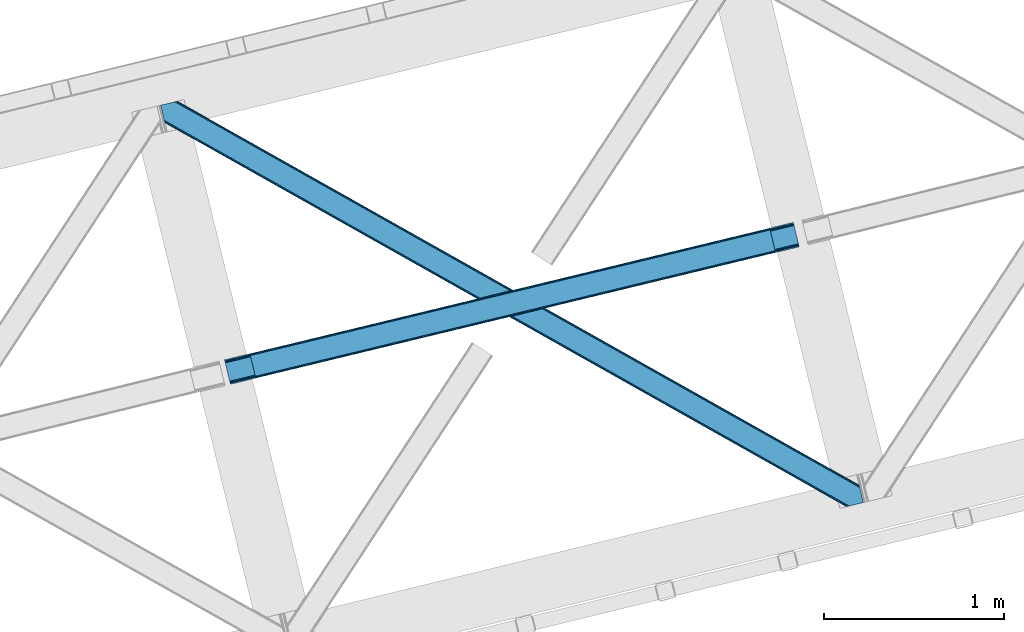
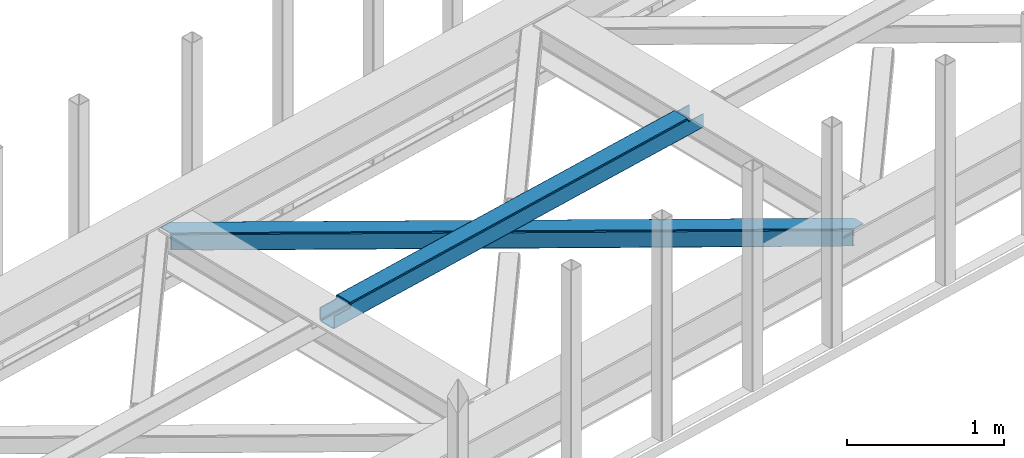
# One storey, part 32 of 66: 1 beam, 1 member.
"""IFC4 building model written with IfcOpenShell, lengths in millimetres."""

from ifc_helpers import new_model, entity, si_unit, converted_unit, derived_unit, direction, frame, origin, place, context, subcontext, project, spatial, triangles, polygons, material, type_object, element, save


model = new_model("IFC4")

# Units and contexts
model_context = context("Model", 3, precision=0.01, world=origin(), true_north=direction((6.12303176911189e-17, 1.0)))
plan_context = context("Plan", 3, precision=0.01, world=origin(), true_north=direction((6.12303176911189e-17, 1.0)))
body_context = subcontext(model_context, "Body", "Model", "MODEL_VIEW")
ifc_project = project(units=[si_unit("LENGTHUNIT", "METRE", prefix="MILLI"), si_unit("AREAUNIT", "SQUARE_METRE"), si_unit("VOLUMEUNIT", "CUBIC_METRE"), converted_unit("PLANEANGLEUNIT", "DEGREE", entity("IfcRatioMeasure", 0.0174532925199433), si_unit("PLANEANGLEUNIT", "RADIAN"), dimensions=[0, 0, 0, 0, 0, 0, 0]), si_unit("MASSUNIT", "GRAM", prefix="KILO"), derived_unit("MASSDENSITYUNIT", [(si_unit("MASSUNIT", "GRAM", prefix="KILO"), 1), (si_unit("LENGTHUNIT", "METRE"), -3)]), derived_unit("MOMENTOFINERTIAUNIT", [(si_unit("LENGTHUNIT", "METRE"), 4)]), si_unit("TIMEUNIT", "SECOND"), si_unit("FREQUENCYUNIT", "HERTZ"), si_unit("THERMODYNAMICTEMPERATUREUNIT", "DEGREE_CELSIUS"), derived_unit("THERMALTRANSMITTANCEUNIT", [(si_unit("MASSUNIT", "GRAM", prefix="KILO"), 1), (si_unit("THERMODYNAMICTEMPERATUREUNIT", "KELVIN"), -1), (si_unit("TIMEUNIT", "SECOND"), -3)]), derived_unit("VOLUMETRICFLOWRATEUNIT", [(si_unit("LENGTHUNIT", "METRE"), 3), (si_unit("TIMEUNIT", "SECOND"), -1)]), derived_unit("MASSFLOWRATEUNIT", [(si_unit("MASSUNIT", "GRAM", prefix="KILO"), 1), (si_unit("TIMEUNIT", "SECOND"), -1)]), derived_unit("ROTATIONALFREQUENCYUNIT", [(si_unit("TIMEUNIT", "SECOND"), -1)]), si_unit("ELECTRICCURRENTUNIT", "AMPERE"), si_unit("ELECTRICVOLTAGEUNIT", "VOLT"), si_unit("POWERUNIT", "WATT"), si_unit("FORCEUNIT", "NEWTON", prefix="KILO"), si_unit("ILLUMINANCEUNIT", "LUX"), si_unit("LUMINOUSFLUXUNIT", "LUMEN"), si_unit("LUMINOUSINTENSITYUNIT", "CANDELA"), derived_unit("USERDEFINED", [(si_unit("MASSUNIT", "GRAM", prefix="KILO"), -1), (si_unit("LENGTHUNIT", "METRE"), -2), (si_unit("TIMEUNIT", "SECOND"), 3), (si_unit("LUMINOUSFLUXUNIT", "LUMEN"), 1)]), derived_unit("LINEARVELOCITYUNIT", [(si_unit("LENGTHUNIT", "METRE"), 1), (si_unit("TIMEUNIT", "SECOND"), -1)]), si_unit("PRESSUREUNIT", "PASCAL"), derived_unit("USERDEFINED", [(si_unit("LENGTHUNIT", "METRE"), -2), (si_unit("MASSUNIT", "GRAM", prefix="KILO"), 1), (si_unit("TIMEUNIT", "SECOND"), -2)]), derived_unit("LINEARFORCEUNIT", [(si_unit("MASSUNIT", "GRAM", prefix="KILO"), 1), (si_unit("LENGTHUNIT", "METRE"), 1), (si_unit("TIMEUNIT", "SECOND"), -2), (si_unit("LENGTHUNIT", "METRE"), -1)]), derived_unit("PLANARFORCEUNIT", [(si_unit("MASSUNIT", "GRAM", prefix="KILO"), 1), (si_unit("LENGTHUNIT", "METRE"), 1), (si_unit("TIMEUNIT", "SECOND"), -2), (si_unit("LENGTHUNIT", "METRE"), -2)])], contexts=[model_context, plan_context])

# Site, building, storey
site_placement = place(None, origin())
site = spatial("IfcSite", under=ifc_project, at=site_placement, CompositionType="ELEMENT")
building_placement = place(site_placement, origin())
building = spatial("IfcBuilding", under=site, at=building_placement, CompositionType="ELEMENT")
storey_placement = place(building_placement, frame((0.0, 0.0, 19800.0)))
storey = spatial("IfcBuildingStorey", under=building, at=storey_placement, Name="06", CompositionType="ELEMENT", Elevation=19800.0)

# Beam
ifc_material = material(Name="Metal painted (White)")
beam_type = type_object("IfcBeamType", PredefinedType="BEAM")
beam_placement = place(storey_placement, frame((-39359.61, 9545.57, 3967.03)))
element("IfcBeam", 1, at=beam_placement, inside=storey, type_object=beam_type, material=ifc_material, ObjectType="Steel Beam", PredefinedType="BEAM", context=body_context, shape_type="Tessellation", body=[
    polygons([(27.353470961905, 23.8030752188062, 7.0000598235344), (28.9394891671779, 17.2966162719668, 8.33217213033355), (3188.12645728267, 780.539347460429, 9.29712245828728), (3186.55413874494, 787.049116173921, 7.96501433595093), (30.2840504779923, 11.7807067185854, 12.1256988935852), (3189.45863568933, 775.020446263414, 13.0906454392703), (31.1824576232485, 8.09509378632021, 17.8031100519825), (3190.34786187874, 771.332615261155, 18.7680537934142), (31.4979362591613, 6.80087863394741, 24.5000712225218), (3190.65875922441, 770.037293293477, 25.465013564638), (1.65778611891462, 129.216694044932, 24.4999947032322), (1.97326475483608, 127.922478892558, 17.8030351506566), (3161.38389125856, 891.219244755388, 18.7680537934142), (3161.0691284579, 892.513632849746, 25.465013564638), (2.87167190008358, 124.23686596029, 12.1256285998416), (3162.27639442246, 887.532205452699, 13.0906454392703), (4.21623321089799, 118.720956406912, 8.3321087323268), (3163.61076243349, 882.013833252429, 9.29712245828728), (5.80225141617086, 112.214497460073, 7.00000455960104), (3165.18384985803, 875.504250297889, 7.96501433595093), (8.66293703438714e-12, 136.017572678875, 17.4999901436355), (0.315478635912791, 134.723357526499, 10.8030305910599), (1.21388578116896, 131.037744594233, 5.12562404024054), (2.55844709199203, 125.521835040854, 1.33210417273009), (4.1444652972649, 119.015376094016, 0.0), (29.0112570808023, 17.002196584861, 6.37660776192206e-05), (30.5972752860752, 10.4957376380216, 1.3321760728811), (31.9418365968809, 4.97982808464235, 5.12570283613275), (32.8402437421458, 1.29421515237713, 10.8031139945301), (33.1557223780586, 3.24860138789518e-12, 17.5000751650737), (33.1557223780586, 1.08286712929839e-12, 104.492615519572), (31.4979362591526, 6.80087863394633, 104.492615519572), (1.6577861188973, 129.21669404493, 104.492615519572), (0.0, 136.017572678875, 104.492615519572), (3159.42728026612, 899.318362001921, 18.4650138731615), (3159.39928415555, 899.311598290844, 115.472391628142), (3161.04315253146, 892.507357204385, 115.472391628137), (3190.63278329797, 770.031017648118, 115.472391628137), (3192.27665167388, 763.226776561658, 115.472391628137), (3192.30464778445, 763.233540272735, 18.4650138731615), (3191.99375043879, 764.528862240413, 11.7680541019377), (3191.10452424939, 768.216693242674, 6.09064574779806), (3189.77234584272, 773.735594439689, 2.29712276681504), (3188.200027305, 780.245363153179, 0.965014644474365), (3163.54200166624, 882.308979450066, 0.965014644474365), (3161.96891424171, 888.818562404604, 2.29712276681504), (3160.63454623068, 894.336934604878, 6.09064574779806), (3159.74204306677, 898.023973907563, 11.7680541019377), (161.750823822574, 38.2692819454433, 104.492615519559), (165.531158526742, 39.1825906585835, 106.103528223035), (169.311493230918, 40.0958993717227, 107.714440926506), (170.877359135682, 40.4742042273367, 111.603528223046), (172.443225040463, 40.8525090829539, 115.492615519574), (3059.3968274947, 738.325110290198, 116.424924587822), (3059.39682749469, 738.325110290198, 115.472391628142), (163.408609941463, 31.4684033114959, 104.492615519598), (167.188944645622, 32.3817120246361, 106.103528223082), (170.969279349807, 33.2950207377775, 107.71444092654), (172.535145254588, 33.6733255933936, 111.603528223046), (174.10101115936, 34.0516304490098, 115.492615519574), (3061.0546136136, 731.524231656253, 115.472391628142), (3061.0546136136, 731.524231656253, 123.424929147419), (174.10101115936, 34.0516304490109, 122.543130490485), (140.945288781319, 170.069203127884, 115.492615519574), (142.60293422888, 163.268906601355, 115.492734192455), (142.918741097907, 161.973333198349, 122.239852351631), (143.816960681394, 158.288496409301, 127.91742174054), (145.161521992199, 152.772586855922, 131.710948503787), (146.747540197472, 146.266127909081, 133.04306081059), (168.298759743206, 57.8547056678149, 133.043116074524), (169.884777948479, 51.3482467209744, 131.711011901798), (171.229339259285, 45.832337167593, 127.917492034279), (172.127746404541, 42.14672423533, 122.24008548346), (173.785532523456, 35.3458456013869, 129.240090043056), (172.8871253782, 39.03145853365, 134.91749659388), (171.542564067385, 44.5473680870303, 138.711016461395), (169.956545862112, 51.0538270338696, 140.04312063412), (145.089754078575, 153.067006543024, 140.043056868043), (143.503735873302, 159.573465489864, 138.710944561244), (142.159174562479, 165.089375043246, 134.917417797992), (141.260767417223, 168.774987975509, 129.24000663959), (140.945288781319, 170.069203127884, 122.543045469051), (3027.89889123554, 867.541804335125, 115.472391628142), (3027.89889123554, 867.541804335125, 123.424844125981), (3028.21436987146, 866.24758918275, 130.121805296524), (3029.11277701672, 862.561976250487, 135.799216454922), (3030.45733832753, 857.046066697107, 139.592743218173), (3032.04335653281, 850.539607750265, 140.924855524977), (3056.91014831634, 748.526428241115, 140.92491929105), (3058.49616652162, 742.019969294273, 139.592815118324), (3059.84072783243, 736.504059740891, 135.79929525081), (3060.73913497768, 732.81844680863, 130.121888699995), (3059.08134885878, 739.619325442571, 123.121884140394), (3058.18294171352, 743.304938374836, 128.799290691213), (3056.83838040271, 748.820847928216, 132.592810558728), (3055.25236219744, 755.327306875058, 133.924914731454), (3033.7011426517, 843.738729116322, 133.92485946752), (3032.11512444643, 850.245188063164, 132.592747160721), (3030.77056313562, 855.761097616546, 128.799220397465), (3029.87196706965, 859.447492315395, 123.121968615998), (3029.55686627516, 860.74014393459, 116.424688691599), (3029.55667735445, 860.740925701182, 115.472391628137), (141.037208995435, 162.890019638321, 111.603528223046), (139.471343090654, 162.511714782705, 107.714440926519), (135.691008386478, 161.598406069563, 106.103528223061), (131.91067368231, 160.685097356424, 104.492615519585), (139.379422876529, 169.690898272263, 111.603528223046), (137.813556971757, 169.312593416649, 107.714440926506), (134.033222267598, 168.399284703513, 106.103528223009), (130.252887563421, 167.485975990372, 104.492615519546)], [[[1, 2, 3, 4]], [[2, 5, 6, 3]], [[5, 7, 8, 6]], [[7, 9, 10, 8]], [[11, 12, 13, 14]], [[12, 15, 16, 13]], [[15, 17, 18, 16]], [[17, 19, 20, 18]], [[19, 1, 4, 20]], [[21, 22, 23, 24, 25, 26, 27, 28, 29, 30, 31, 32, 9, 7, 5, 2, 1, 19, 17, 15, 12, 11, 33, 34]], [[35, 36, 37, 14, 13, 16, 18, 20, 4, 3, 6, 8, 10, 38, 39, 40, 41, 42, 43, 44, 45, 46, 47, 48]], [[9, 32, 49, 50, 51, 52, 53, 54, 55, 38, 10]], [[56, 57, 50, 49]], [[57, 58, 51, 50]], [[58, 59, 52, 51]], [[59, 60, 53, 52]], [[56, 49, 32, 31]], [[56, 31, 30, 40, 39, 61, 62, 63, 60, 59, 58, 57]], [[64, 65, 66, 67, 68, 69, 70, 71, 72, 73, 53, 60, 63, 74, 75, 76, 77, 78, 79, 80, 81, 82]], [[61, 39, 38, 55]], [[83, 84, 85, 86, 87, 88, 89, 90, 91, 92, 62, 61, 55, 54, 93, 94, 95, 96, 97, 98, 99, 100, 101, 102]], [[96, 95, 71, 70]], [[95, 94, 72, 71]], [[94, 93, 73, 72]], [[93, 54, 53, 73]], [[70, 69, 97, 96]], [[101, 100, 66, 65]], [[100, 99, 67, 66]], [[99, 98, 68, 67]], [[98, 97, 69, 68]], [[33, 11, 14, 37, 102, 101, 65, 103, 104, 105, 106]], [[64, 107, 103, 65]], [[107, 108, 104, 103]], [[108, 109, 105, 104]], [[109, 110, 106, 105]], [[34, 33, 106, 110]], [[36, 83, 102, 37]], [[30, 29, 41, 40]], [[29, 28, 42, 41]], [[28, 27, 43, 42]], [[27, 26, 44, 43]], [[44, 26, 25, 45]], [[25, 24, 46, 45]], [[24, 23, 47, 46]], [[23, 22, 48, 47]], [[22, 21, 35, 48]], [[35, 21, 34, 110, 109, 108, 107, 64, 82, 84, 83, 36]], [[62, 92, 74, 63]], [[92, 91, 75, 74]], [[91, 90, 76, 75]], [[90, 89, 77, 76]], [[88, 78, 77, 89]], [[88, 87, 79, 78]], [[87, 86, 80, 79]], [[86, 85, 81, 80]], [[85, 84, 82, 81]]], closed=True),
])

# Member
member_type = type_object("IfcMemberType", PredefinedType="BRACE")
member_placement = place(storey_placement, frame((-39714.51, 8865.52, 3824.0)))
element("IfcMember", 2, at=member_placement, inside=storey, type_object=member_type, ObjectType="Steel Horizontal Brace", PredefinedType="BRACE", context=body_context, shape_type="Tessellation", body=[
    triangles([(3809.33957519531, 0.0, 122.499499511719), (3811.23480834961, 0.462181091308594, 129.196765136719), (23.4590332031294, 2133.54767761231, 129.196765136719), (23.8869140625029, 2131.77569274902, 122.499499511719), (3816.62982788086, 1.77721710205151, 134.87548828125), (22.2265502929731, 2138.59388122559, 134.87548828125), (3824.70375366211, 3.74512023925854, 138.668280029298), (20.3848022460952, 2146.14690856934, 138.668280029298), (3834.22875366211, 6.06707153320349, 140.00075683594), (18.2128417968779, 2155.05566711426, 140.00075683594), (1916.9806640625, 1065.68146362305, 17.5012573242202), (2556.11607055664, 705.752851867675, 17.5012573242202), (3195.24915161133, 345.823658752443, 17.5012573242202), (3809.33957519531, 0.0, 17.5012573242202), (1277.84525756836, 1425.61065673828, 17.5012573242202), (638.709851074222, 1785.53868713379, 17.5012573242202), (23.8869140625029, 2131.77569274902, 17.5012573242202), (3885.46051025391, 97.721360778809, 140.00075683594), (3903.67567749024, 22.9951080322262, 140.00075683594), (69.4469238281235, 2246.709375, 140.00075683594), (0.0, 2229.78133850098, 140.00075683594), (3883.28854980469, 106.63011932373, 138.668280029298), (78.971923828125, 2249.03132629395, 138.668280029298), (3881.44680175781, 114.182565307618, 134.87548828125), (87.0458496093779, 2250.99981079102, 134.87548828125), (3880.21664428711, 119.229350280762, 129.196765136719), (92.4408691406279, 2252.31600952148, 129.196765136719), (3879.78643798828, 121.001335144043, 122.499499511719), (94.3337768554702, 2252.77760925293, 122.499499511719), (3265.41928710938, 466.982542419433, 17.5012573242202), (3879.78643798828, 121.001335144043, 17.5012573242202), (2626.29318237305, 826.905340576172, 17.5012573242202), (1987.16940307617, 1186.82755737305, 17.5012573242202), (708.921844482422, 1906.67315368652, 17.5012573242202), (94.3337768554702, 2252.77760925293, 17.5012573242202), (1348.0456237793, 1546.75093688965, 17.5012573242202), (82.4833374023438, 2249.88825073242, 122.197192382813), (69.0143920898481, 2246.60473022461, 131.668707275392), (59.4893920898467, 2244.28277893066, 133.001184082033), (0.0, 2229.78133850098, 133.001184082033), (77.0883178710938, 2248.57321472168, 127.873590087893), (84.3808959960952, 2250.34985046387, 24.5008300781265), (77.0883178710938, 2248.57321472168, 12.1248413085959), (91.5851074218735, 2252.1067199707, 9.49942016601563), (82.4833374023438, 2249.88825073242, 17.8035644531265), (84.3808959960952, 2250.34985046387, 115.499926757813), (72.3118652343765, 2247.40816955567, 9.49942016601563), (92.0548461914077, 2252.22066650391, 10.8691040039084), (1983.48823242188, 1180.86745605469, 24.5008300781265), (3882.05606689453, 111.689694213868, 115.499926757813), (2626.78617553711, 818.593057250977, 24.5008300781265), (3270.08876953125, 456.31923980713, 24.5008300781265), (3882.05606689453, 111.689694213868, 24.5008300781265), (1340.18796386719, 1543.14069213867, 24.5008300781265), (696.8876953125, 1905.41509094238, 24.5008300781265), (3882.48627319336, 109.917127990722, 122.197192382813), (3883.71643066406, 104.870924377441, 127.873590087893), (3885.55817871094, 97.3184783935558, 131.668707275392), (3887.73013916016, 88.4097198486324, 133.001184082033), (3883.71643066406, 104.870924377441, 12.1248413085959), (3885.4163269043, 97.899838256837, 8.52041015625218), (3880.58871459961, 117.702699279786, 8.52041015625218), (3903.67567749024, 22.9951080322262, 133.001184082033), (3882.48627319336, 109.917127990722, 17.8035644531265), (3880.37244873047, 118.590435791017, 10.9365417480476), (3844.18628540039, 8.49424896240271, 133.001184082033), (15.9432128906265, 2164.3678894043, 133.001184082033), (3834.66128540039, 6.17229766845776, 131.668707275392), (18.1151733398438, 2155.45796813965, 131.668707275392), (3826.58735961915, 4.20439453125073, 127.873590087893), (19.9569213867217, 2147.90610351562, 127.873590087893), (3821.19001464844, 2.88819580078234, 122.197192382813), (21.1894042968779, 2142.85989990234, 122.197192382813), (3819.29478149414, 2.42717742919922, 115.499926757813), (21.6172851562515, 2141.08791503906, 115.499926757813), (3208.50183105469, 346.395716857911, 24.5008300781265), (3819.29478149414, 2.42717742919922, 24.5008300781265), (2565.16435546875, 708.690463256837, 24.5008300781265), (1921.82687988281, 1070.98579101563, 24.5008300781265), (635.15192871094, 1795.57528381348, 24.5008300781265), (21.6172851562515, 2141.08791503906, 24.5008300781265), (1278.49172973633, 1433.27995605469, 24.5008300781265), (21.1894042968779, 2142.85989990234, 17.8035644531265), (23.2590454101592, 2134.34995422363, 9.49942016601563), (19.9569213867217, 2147.90610351562, 12.1248413085959), (23.3706665039063, 2133.90928344727, 10.8691040039084), (18.8686157226548, 2152.37676086426, 9.49942016601563), (3826.58735961915, 4.20439453125073, 12.1248413085959), (3812.86494140625, 0.859831237792605, 8.52041015625218), (3821.19001464844, 2.88819580078234, 17.8035644531265), (3834.03806762696, 6.02056274414099, 8.52041015625218), (3811.91616210937, 0.628450012207395, 10.9365417480476), (190.667431640628, 2055.62685241699, 9.49942016601563), (195.062512207034, 2037.60120849609, 9.49942016601563), (196.076403808598, 2037.66864624023, 8.49948120117188), (196.053149414067, 2037.42331237793, 8.8831787109375), (191.290649414063, 2056.67097473145, 8.85294799804615), (195.732238769531, 2037.48144836426, 9.08316650390771), (191.346459960936, 2055.82567749023, 9.20641479492406), (195.383422851563, 2037.54307250977, 9.29943237304906), (191.006945800786, 2055.72684631348, 9.35291748046802), (191.234838867189, 2057.51627197266, 8.49948120117188), (150.921020507813, 2218.6901550293, 9.49942016601563), (155.311450195317, 2200.6645111084, 9.49942016601563), (151.251232910159, 2218.34947814941, 9.25757446289208), (155.813745117186, 2200.23779296875, 9.42500610351635), (151.60469970703, 2217.98438415527, 8.99945068359375), (156.250927734378, 2199.30529174805, 9.11804809570458), (151.962817382817, 2217.61929016113, 8.74132690429906), (156.692761230472, 2198.36348876953, 8.80643920898365), (152.293029785156, 2217.27861328125, 8.49948120117188), (157.129943847656, 2197.43215026855, 8.49948120117188), (3713.61518554688, 194.649165344239, 8.52041015625218), (3708.78989868164, 214.452026367188, 8.52041015625218), (3713.26636962891, 194.529986572266, 8.40181274414135), (3708.39689941407, 214.570623779297, 8.37390747070458), (3713.06173095703, 194.459642028809, 8.3320495605476), (3708.00390014648, 214.689221191407, 8.22740478515698), (3707.90390625, 214.477606201172, 7.87393798828271), (3713.112890625, 193.949789428711, 8.19484863281468), (3707.80391235352, 214.265991210938, 7.52047119140843), (3713.23846435547, 192.705097961427, 7.85765991211156), (3713.36403808594, 191.464476013183, 7.52047119140843), (3264.76351318359, 465.821566772462, 10.8039916992202), (3262.90316162109, 462.516535949708, 5.12526855468968), (3260.1149597168, 457.569163513184, 1.33247680664135), (3708.58060913086, 211.08769683838, 5.59500732422021), (708.268395996092, 1905.51275939941, 10.8039916992202), (706.405718994145, 1902.2071472168, 5.12526855468968), (153.148791503911, 2213.77533874512, 5.12526855468968), (703.619842529297, 1897.25977478027, 1.33247680664135), (154.985888671879, 2206.22231140137, 1.33247680664135), (700.333996582034, 1891.42524719238, 0.0), (157.157849121097, 2197.31355285645, 0.0), (3710.29445800781, 204.051498413086, 1.33247680664135), (3712.46641845704, 195.142739868164, 0.0), (3256.82911376953, 451.73405456543, 0.0), (2625.63973388672, 825.7443649292, 10.8039916992202), (1986.5136291504, 1185.66716308594, 10.8039916992202), (1347.39217529297, 1545.59054260254, 10.8039916992202), (2623.77938232422, 822.439334106446, 5.12526855468968), (1984.6532775879, 1182.36155090332, 5.12526855468968), (1345.53182373047, 1542.28493041992, 5.12526855468968), (2620.99350585938, 817.492543029786, 1.33247680664135), (1981.86740112305, 1177.4141784668, 1.33247680664135), (1342.74362182617, 1537.3375579834, 1.33247680664135), (2617.70765991211, 811.656852722168, 0.0), (1978.58155517578, 1171.57965087891, 0.0), (1339.45777587891, 1531.50303039551, 0.0), (3746.51550292969, 55.4634750366222, 0.0), (3203.83699951172, 361.072146606446, 0.0), (2564.70391845703, 721.001339721681, 0.0), (1925.56618652344, 1080.92937011719, 0.0), (1286.43310546875, 1440.85856323242, 0.0), (647.300024414064, 1800.78775634766, 0.0), (191.206933593749, 2057.63486938477, 0.0), (3195.90492553711, 346.985215759278, 10.8039916992202), (639.365624999999, 1786.6990814209, 10.8039916992202), (641.225976562499, 1790.00469360352, 5.12526855468968), (195.220642089844, 2041.17308349609, 5.12526855468968), (3197.76527709961, 350.290246582032, 5.12526855468968), (3200.55115356445, 355.237037658691, 1.33247680664135), (3748.6874633789, 46.554135131837, 1.33247680664135), (3752.57792358399, 34.8100845336921, 8.52041015625218), (3750.40131225586, 39.517936706543, 5.59500732422021), (3751.17568359375, 36.3396423339855, 7.52047119140843), (3752.23840942383, 35.1804107666012, 8.278564453125), (644.011853027347, 1794.95206604004, 1.33247680664135), (193.378894042973, 2048.72611083984, 1.33247680664135), (2561.41574707031, 715.165649414063, 1.33247680664135), (1922.28266601563, 1075.0948425293, 1.33247680664135), (1283.14725952149, 1435.0228729248, 1.33247680664135), (2558.63219604492, 710.218858337403, 5.12526855468968), (1919.49446411133, 1070.14747009277, 5.12526855468968), (1280.36138305664, 1430.07666320801, 5.12526855468968), (2556.76951904297, 706.913246154785, 10.8039916992202), (1917.63411254883, 1066.84185791016, 10.8039916992202), (1278.50103149414, 1426.77105102539, 10.8039916992202), (3745.61788330078, 59.1411575317379, 7.52047119140843), (3746.13645629883, 57.3430114746097, 7.90416870117406), (3746.6736328125, 56.436090087891, 8.10880737304615), (3747.29917602539, 55.37627105713, 8.34832763671875), (3747.7503112793, 54.6129455566406, 8.52041015625218), (3211.01563110352, 350.861723327636, 12.1248413085959), (3217.08735351563, 361.643623352051, 6.99957275390625), (3213.80150756836, 355.808514404298, 8.3320495605476), (3744.24587402344, 64.7751159667969, 6.99957275390625), (643.742102050783, 1810.82319030762, 6.99957275390625), (188.937304687504, 2066.94592895508, 6.99957275390625), (637.668054199217, 1800.0412902832, 12.1248413085959), (640.458581542967, 1804.98866271973, 8.3320495605476), (635.807702636717, 1796.73567810059, 17.8035644531265), (3209.15527954102, 347.556111145021, 17.8035644531265), (2565.81780395508, 709.850857543946, 17.8035644531265), (1922.48032836914, 1072.14618530273, 17.8035644531265), (1279.1428527832, 1434.4403503418, 17.8035644531265), (2567.67815551758, 713.156469726562, 12.1248413085959), (1924.3430053711, 1075.45179748535, 12.1248413085959), (1281.00785522461, 1437.74712524414, 12.1248413085959), (2570.46403198242, 718.103260803224, 8.3320495605476), (1927.12888183594, 1080.39800720215, 8.3320495605476), (1283.79373168945, 1442.69333496094, 8.3320495605476), (2573.74987792969, 723.938369750977, 6.99957275390625), (1930.41705322266, 1086.23369750977, 6.99957275390625), (1287.07957763672, 1448.52902526856, 6.99957275390625), (694.371569824223, 1900.94908447266, 12.1248413085959), (691.590344238284, 1896.00287475586, 8.3320495605476), (157.264819335942, 2196.88450927734, 8.41343994140698), (159.427478027348, 2188.00133056641, 6.99957275390625), (3261.50092163086, 441.070751953126, 6.99957275390625), (3264.78676757812, 446.906442260743, 8.3320495605476), (3714.73604736328, 185.830517578126, 6.99957275390625), (3267.57264404297, 451.852651977539, 12.1248413085959), (688.302172851567, 1890.16718444824, 6.99957275390625), (696.236572265625, 1904.25469665527, 17.8035644531265), (3269.43532104493, 455.158264160156, 17.8035644531265), (2621.48649902344, 809.179678344726, 8.3320495605476), (2618.20065307617, 803.344569396973, 6.99957275390625), (1978.18855590821, 1171.45407714844, 8.3320495605476), (1974.90038452148, 1165.61838684082, 6.99957275390625), (1331.60244140625, 1527.89278564453, 6.99957275390625), (1334.88828735352, 1533.72847595215, 8.3320495605476), (2624.27470092774, 814.12705078125, 12.1248413085959), (1980.97210693359, 1176.40144958496, 12.1248413085959), (1337.67416381836, 1538.67468566895, 12.1248413085959), (2626.13505249024, 817.432081604004, 17.8035644531265), (1982.83478393555, 1179.70706176758, 17.8035644531265), (1339.53451538086, 1541.98029785156, 17.8035644531265)], [[1, 2, 3], [3, 4, 1], [2, 5, 6], [6, 3, 2], [5, 7, 8], [8, 6, 5], [7, 9, 10], [10, 8, 7], [11, 1, 4], [1, 12, 13], [11, 12, 1], [13, 14, 1], [15, 4, 16], [4, 15, 11], [17, 16, 4], [9, 18, 10], [9, 19, 18], [20, 10, 18], [21, 10, 20], [18, 22, 23], [23, 20, 18], [22, 24, 25], [25, 23, 22], [24, 26, 27], [27, 25, 24], [26, 28, 29], [29, 27, 26], [30, 28, 31], [28, 30, 32], [28, 33, 29], [33, 28, 32], [34, 35, 29], [36, 29, 33], [29, 36, 34], [37, 29, 27], [38, 23, 20], [21, 39, 20], [39, 21, 40], [39, 38, 20], [41, 23, 38], [41, 37, 25], [25, 23, 41], [27, 25, 37], [42, 35, 29], [43, 44, 45], [37, 46, 29], [43, 47, 44], [42, 45, 35], [46, 42, 29], [48, 35, 45], [45, 44, 48], [49, 50, 46], [50, 51, 52], [49, 51, 50], [52, 53, 50], [54, 46, 55], [46, 54, 49], [42, 55, 46], [50, 56, 46], [37, 46, 56], [56, 57, 37], [41, 37, 57], [57, 58, 41], [38, 41, 58], [58, 59, 38], [39, 38, 59], [57, 24, 22], [60, 61, 62], [24, 57, 56], [58, 57, 22], [58, 18, 59], [19, 59, 18], [59, 19, 63], [58, 22, 18], [31, 28, 53], [62, 64, 60], [64, 31, 53], [65, 64, 62], [65, 31, 64], [28, 50, 53], [56, 26, 24], [28, 26, 56], [50, 28, 56], [59, 66, 67], [66, 59, 63], [67, 39, 59], [40, 39, 67], [66, 68, 67], [69, 67, 68], [68, 70, 69], [71, 69, 70], [70, 72, 71], [73, 71, 72], [72, 74, 73], [75, 73, 74], [76, 74, 77], [74, 76, 78], [74, 79, 75], [79, 74, 78], [80, 81, 75], [82, 75, 79], [75, 82, 80], [83, 84, 85], [81, 4, 17], [17, 86, 83], [86, 84, 83], [83, 81, 17], [75, 4, 81], [73, 71, 6], [3, 73, 6], [3, 4, 73], [75, 73, 4], [71, 8, 6], [69, 8, 71], [87, 85, 84], [69, 67, 10], [69, 10, 8], [67, 21, 10], [67, 40, 21], [72, 1, 2], [68, 7, 9], [19, 66, 9], [66, 19, 63], [66, 68, 9], [70, 7, 68], [70, 72, 5], [5, 7, 70], [2, 5, 72], [77, 14, 1], [88, 89, 90], [72, 74, 1], [88, 91, 89], [77, 90, 14], [74, 77, 1], [92, 14, 90], [90, 89, 92], [93, 94, 84], [84, 87, 93], [95, 96, 97], [96, 98, 99], [99, 98, 100], [101, 100, 94], [94, 93, 101], [100, 101, 99], [99, 97, 96], [97, 102, 95], [103, 104, 44], [47, 44, 104], [105, 106, 104], [107, 108, 106], [109, 110, 108], [111, 112, 110], [110, 109, 111], [108, 107, 109], [106, 105, 107], [104, 103, 105], [62, 61, 113], [113, 114, 62], [115, 116, 114], [117, 118, 116], [116, 115, 117], [119, 118, 120], [121, 119, 122], [122, 123, 121], [120, 122, 119], [117, 120, 118], [114, 113, 115], [124, 30, 31], [125, 124, 118], [118, 119, 125], [119, 121, 125], [124, 65, 114], [114, 116, 124], [116, 118, 124], [65, 62, 114], [126, 125, 127], [48, 128, 103], [128, 129, 130], [130, 111, 128], [128, 109, 107], [109, 128, 111], [128, 105, 103], [105, 128, 107], [128, 48, 35], [35, 34, 128], [103, 44, 48], [129, 131, 132], [132, 130, 129], [131, 133, 134], [134, 132, 131], [135, 136, 137], [137, 126, 135], [127, 135, 126], [121, 127, 125], [31, 65, 124], [30, 124, 138], [138, 32, 30], [32, 138, 33], [139, 33, 138], [33, 139, 36], [140, 36, 139], [36, 140, 34], [128, 34, 140], [124, 125, 138], [141, 138, 125], [138, 141, 142], [142, 139, 138], [139, 142, 143], [143, 140, 139], [140, 143, 129], [129, 128, 140], [125, 126, 144], [144, 141, 125], [141, 144, 145], [145, 142, 141], [142, 145, 146], [146, 143, 142], [143, 146, 129], [131, 129, 146], [126, 137, 144], [147, 144, 137], [144, 147, 145], [148, 145, 147], [145, 148, 146], [149, 146, 148], [146, 149, 131], [133, 131, 149], [136, 150, 151], [137, 151, 147], [151, 137, 136], [148, 152, 153], [152, 147, 151], [148, 147, 152], [133, 149, 154], [153, 149, 148], [149, 153, 154], [155, 133, 154], [156, 133, 155], [134, 133, 156], [157, 92, 14], [158, 16, 17], [159, 96, 95], [158, 86, 94], [94, 159, 158], [94, 98, 159], [86, 84, 94], [95, 160, 159], [161, 162, 163], [92, 157, 164], [157, 161, 165], [165, 166, 157], [167, 164, 157], [157, 166, 167], [164, 89, 92], [163, 165, 161], [150, 163, 162], [162, 151, 150], [155, 168, 169], [169, 156, 155], [168, 159, 160], [160, 169, 168], [17, 86, 158], [14, 13, 157], [151, 162, 152], [170, 152, 162], [152, 170, 171], [171, 153, 152], [153, 171, 172], [172, 154, 153], [154, 172, 168], [168, 155, 154], [162, 161, 173], [173, 170, 162], [170, 173, 171], [174, 171, 173], [171, 174, 172], [175, 172, 174], [172, 175, 168], [159, 168, 175], [161, 157, 176], [176, 173, 161], [173, 176, 174], [177, 174, 176], [174, 177, 175], [178, 175, 177], [175, 178, 159], [158, 159, 178], [157, 13, 12], [12, 176, 157], [176, 12, 11], [11, 177, 176], [177, 11, 15], [15, 178, 177], [178, 15, 16], [16, 158, 178], [166, 179, 180], [166, 180, 181], [167, 181, 182], [167, 182, 183], [91, 89, 183], [164, 183, 89], [184, 183, 182], [88, 91, 183], [183, 184, 88], [185, 180, 179], [182, 185, 186], [182, 181, 185], [180, 185, 181], [179, 187, 185], [188, 189, 102], [93, 85, 190], [93, 87, 85], [102, 190, 191], [190, 102, 97], [97, 99, 190], [80, 192, 81], [83, 81, 192], [192, 190, 83], [85, 83, 190], [102, 191, 188], [182, 186, 184], [90, 88, 184], [184, 193, 90], [77, 90, 193], [193, 76, 77], [76, 193, 78], [194, 78, 193], [78, 194, 195], [195, 79, 78], [79, 195, 82], [196, 82, 195], [82, 196, 80], [192, 80, 196], [193, 184, 197], [197, 194, 193], [194, 197, 195], [198, 195, 197], [195, 198, 196], [199, 196, 198], [196, 199, 190], [190, 192, 196], [184, 186, 197], [200, 197, 186], [197, 200, 198], [201, 198, 200], [198, 201, 202], [202, 199, 198], [199, 202, 191], [191, 190, 199], [186, 185, 203], [203, 200, 186], [200, 203, 204], [204, 201, 200], [201, 204, 205], [205, 202, 201], [202, 205, 191], [188, 191, 205], [206, 106, 108], [108, 207, 206], [108, 110, 207], [110, 208, 207], [104, 206, 43], [43, 47, 104], [207, 208, 209], [210, 123, 122], [122, 211, 210], [122, 117, 211], [210, 212, 123], [213, 211, 117], [61, 60, 113], [213, 113, 60], [209, 214, 207], [206, 215, 45], [45, 43, 206], [215, 55, 42], [42, 45, 215], [64, 53, 216], [52, 216, 53], [60, 64, 213], [216, 213, 64], [210, 211, 217], [217, 218, 210], [218, 217, 219], [219, 220, 218], [220, 219, 221], [222, 221, 219], [221, 222, 207], [207, 214, 221], [211, 213, 217], [223, 217, 213], [217, 223, 219], [224, 219, 223], [219, 224, 222], [225, 222, 224], [222, 225, 207], [206, 207, 225], [213, 216, 226], [226, 223, 213], [223, 226, 227], [227, 224, 223], [224, 227, 228], [228, 225, 224], [225, 228, 215], [215, 206, 225], [216, 52, 51], [51, 226, 216], [226, 51, 227], [49, 227, 51], [227, 49, 228], [54, 228, 49], [228, 54, 215], [55, 215, 54], [209, 134, 189], [132, 208, 130], [208, 132, 134], [130, 208, 111], [134, 209, 208], [189, 134, 156], [169, 102, 156], [102, 169, 160], [156, 102, 189], [160, 95, 102], [136, 212, 187], [123, 127, 121], [136, 123, 212], [123, 135, 127], [123, 136, 135], [150, 136, 187], [179, 150, 187], [165, 179, 166], [179, 163, 150], [179, 165, 163], [203, 185, 210], [210, 218, 203], [218, 204, 203], [204, 218, 220], [185, 212, 210], [185, 187, 212], [214, 188, 221], [188, 214, 189], [209, 189, 214], [205, 221, 188], [220, 205, 204], [221, 205, 220]]),
])

save(model, "model.ifc")
